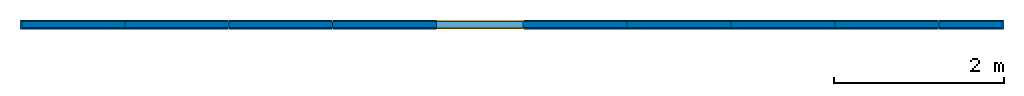
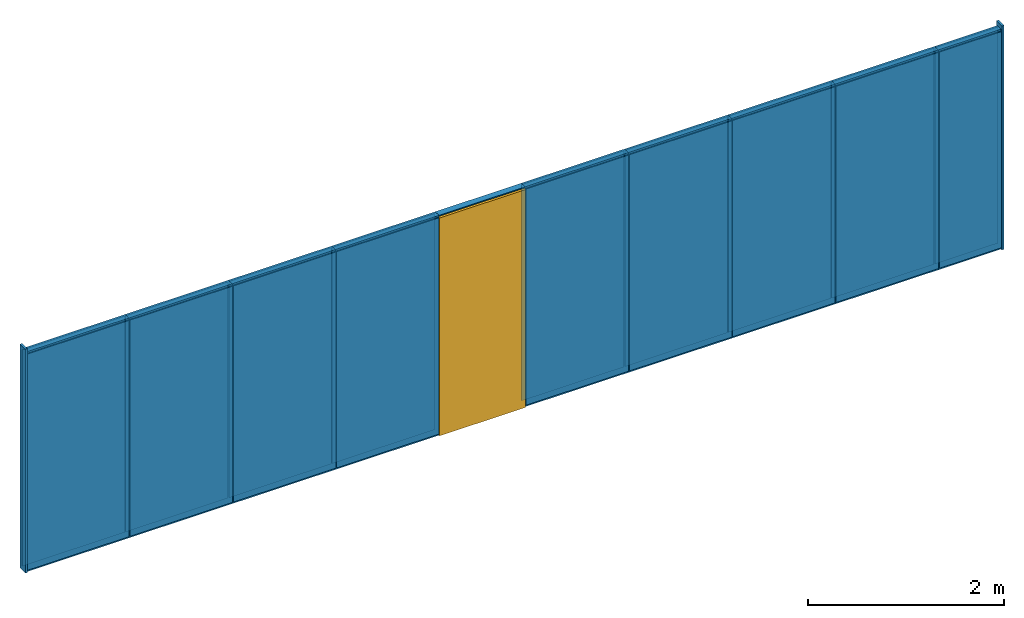
# One storey: 30 walls, 1 door, 1 opening, 1 element without a shape of its own.
"""IFC2X3 building model written with IfcOpenShell, lengths in inches."""

from ifc_helpers import new_model, entity, si_unit, converted_unit, direction, frame, origin, origin_with_axes, origin_2d_with_axis, place, context, subcontext, project, spatial, rectangle, extrude, source, transform, mapped, material, layer, layer_set, layer_usage, type_object, type_shapes, element, fill, aggregate, save


model = new_model("IFC2X3")

# Units and contexts
model_context = context("Model", 3, precision=1e-09, world=origin(), true_north=direction((0.0, 1.0, 0.0)))
context_of_model = context(None, 3, precision=1e-09, world=origin(), true_north=direction((0.0, 1.0, 0.0)))
body_context = subcontext(model_context, "Body", "Model", "MODEL_VIEW")
ifc_project = project(units=[converted_unit("LENGTHUNIT", "inch", entity("IfcReal", 25.4), si_unit("LENGTHUNIT", "METRE", prefix="MILLI"), dimensions=[1, 0, 0, 0, 0, 0, 0]), converted_unit("AREAUNIT", "square foot", entity("IfcReal", 92903.04000000001), si_unit("AREAUNIT", "SQUARE_METRE", prefix="MILLI"), dimensions=[2, 0, 0, 0, 0, 0, 0]), converted_unit("VOLUMEUNIT", "cubic foot", entity("IfcReal", 28316846.592), si_unit("VOLUMEUNIT", "CUBIC_METRE", prefix="MILLI"), dimensions=[3, 0, 0, 0, 0, 0, 0]), converted_unit("PLANEANGLEUNIT", "DEGREE", entity("IfcReal", 0.0174532925199433), si_unit("PLANEANGLEUNIT", "RADIAN"), dimensions=[0, 0, 0, 0, 0, 0, 0]), si_unit("SOLIDANGLEUNIT", "STERADIAN"), si_unit("MASSUNIT", "GRAM"), si_unit("TIMEUNIT", "SECOND"), si_unit("THERMODYNAMICTEMPERATUREUNIT", "DEGREE_CELSIUS"), si_unit("LUMINOUSINTENSITYUNIT", "LUMEN")], contexts=[model_context, context_of_model])

# Site, building, storey
site_placement = place(None, origin_with_axes())
site = spatial("IfcSite", under=ifc_project, at=site_placement, CompositionType="ELEMENT")
building_placement = place(None, origin_with_axes())
building = spatial("IfcBuilding", under=site, at=building_placement, Name="Default Building", CompositionType="ELEMENT")
storey_placement = place(building_placement, origin_with_axes())
storey = spatial("IfcBuildingStorey", under=building, at=storey_placement, Name="Level 1", CompositionType="ELEMENT", Elevation=0.0)

# Walls
wall_type_1 = type_object("IfcWallType", Name="Generic Wall", PredefinedType="NOTDEFINED")
placement_1 = place(storey_placement, origin_with_axes())
wall_1 = element("IfcWallStandardCase", 1, at=placement_1, inside=storey, type_object=wall_type_1, Name="Wall WallSet Option", ObjectType="Wall WallSet Option")
wall_type_2 = type_object("IfcWallType", PredefinedType="NOTDEFINED")
wall_2_placement = place(placement_1, origin_with_axes())
wall_2 = element("IfcWall", 2, at=wall_2_placement, type_object=wall_type_2, context=body_context, shape_type="SweptSolid", body=[
    extrude(rectangle(XDim=29.640015, YDim=3.0, at=origin_2d_with_axis()), frame((211.547287, 0.0, 0.0), z_axis=(0.0, 0.0, 1.0), x_axis=(1.0, 0.0, 0.0)), (0.0, 0.0, 1.0), 108.0),
])
wall_type_3 = type_object("IfcWallType", PredefinedType="NOTDEFINED")
wall_3_placement = place(placement_1, origin_with_axes())
wall_3 = element("IfcWall", 3, at=wall_3_placement, type_object=wall_type_3, context=body_context, shape_type="SweptSolid", body=[
    extrude(rectangle(XDim=48.0, YDim=3.0, at=origin_2d_with_axis()), frame((-203.27272, 0.0, 0.0), z_axis=(0.0, 0.0, 1.0), x_axis=(1.0, 0.0, 0.0)), (0.0, 0.0, 1.0), 108.0),
])
wall_4_placement = place(placement_1, origin_with_axes())
wall_4 = element("IfcWall", 4, at=wall_4_placement, type_object=wall_type_3, context=body_context, shape_type="SweptSolid", body=[
    extrude(rectangle(XDim=48.0, YDim=3.0, at=origin_2d_with_axis()), frame((-107.27272, 0.0, 0.0), z_axis=(0.0, 0.0, 1.0), x_axis=(1.0, 0.0, 0.0)), (0.0, 0.0, 1.0), 108.0),
])
wall_5_placement = place(placement_1, origin_with_axes())
wall_5 = element("IfcWall", 5, at=wall_5_placement, type_object=wall_type_3, context=body_context, shape_type="SweptSolid", body=[
    extrude(rectangle(XDim=48.0, YDim=3.0, at=origin_2d_with_axis()), frame((124.72728, 0.0, 0.0), z_axis=(0.0, 0.0, 1.0), x_axis=(1.0, 0.0, 0.0)), (0.0, 0.0, 1.0), 108.0),
])
wall_6_placement = place(placement_1, origin_with_axes())
wall_6 = element("IfcWall", 6, at=wall_6_placement, type_object=wall_type_3, context=body_context, shape_type="SweptSolid", body=[
    extrude(rectangle(XDim=48.0, YDim=3.0, at=origin_2d_with_axis()), frame((-59.27272, 0.0, 0.0), z_axis=(0.0, 0.0, 1.0), x_axis=(1.0, 0.0, 0.0)), (0.0, 0.0, 1.0), 108.0),
])
wall_7_placement = place(placement_1, origin_with_axes())
wall_7 = element("IfcWall", 7, at=wall_7_placement, type_object=wall_type_3, context=body_context, shape_type="SweptSolid", body=[
    extrude(rectangle(XDim=48.0, YDim=3.0, at=origin_2d_with_axis()), frame((76.72728, 0.0, 0.0), z_axis=(0.0, 0.0, 1.0), x_axis=(1.0, 0.0, 0.0)), (0.0, 0.0, 1.0), 108.0),
])
wall_8_placement = place(placement_1, origin_with_axes())
wall_8 = element("IfcWall", 8, at=wall_8_placement, type_object=wall_type_3, context=body_context, shape_type="SweptSolid", body=[
    extrude(rectangle(XDim=48.0, YDim=3.0, at=origin_2d_with_axis()), frame((172.72728, 0.0, 0.0), z_axis=(0.0, 0.0, 1.0), x_axis=(1.0, 0.0, 0.0)), (0.0, 0.0, 1.0), 108.0),
])
wall_9_placement = place(placement_1, origin_with_axes())
wall_9 = element("IfcWall", 9, at=wall_9_placement, type_object=wall_type_3, context=body_context, shape_type="SweptSolid", body=[
    extrude(rectangle(XDim=48.0, YDim=3.0, at=origin_2d_with_axis()), frame((-155.27272, 0.0, 0.0), z_axis=(0.0, 0.0, 1.0), x_axis=(1.0, 0.0, 0.0)), (0.0, 0.0, 1.0), 108.0),
])
wall_10_placement = place(placement_1, origin_with_axes())
wall_10 = element("IfcWall", 10, at=wall_10_placement, type_object=wall_type_3, context=body_context, shape_type="SweptSolid", body=[
    extrude(rectangle(XDim=48.0, YDim=3.0, at=origin_2d_with_axis()), frame((28.72728, 0.0, 0.0), z_axis=(0.0, 0.0, 1.0), x_axis=(1.0, 0.0, 0.0)), (0.0, 0.0, 1.0), 108.0),
])

# Wall
element("IfcWallStandardCase", 11, at=placement_1, inside=storey, Name="X-Wing End Cap", ObjectType="X-Wing End Cap", context=body_context, shape_type="SweptSolid", body=[
    extrude(rectangle(XDim=4.35, YDim=0.9748, at=origin_2d_with_axis()), frame((226.367294, 0.0, 0.0), z_axis=(0.0, 0.0, 1.0), x_axis=(0.0, -1.0, 0.0)), (0.0, 0.0, 1.0), 109.968506),
])

wall_12_placement = place(placement_1, origin_with_axes())
wall_12 = element("IfcWallStandardCase", 12, at=wall_12_placement, Name="Wall Face Mounted Tile Option", ObjectType="Wall Face Mounted Tile Option", context=body_context, shape_type="SweptSolid", body=[
    extrude(rectangle(XDim=29.285683, YDim=0.5, at=origin_2d_with_axis()), frame((211.545898, -1.75, 1.0), z_axis=(0.0, 0.0, 1.0), x_axis=(1.0, 0.0, 0.0)), (0.0, 0.0, 1.0), 106.198814),
])

wall_13_placement = place(placement_1, origin_with_axes())
wall_13 = element("IfcWallStandardCase", 13, at=wall_13_placement, Name="Wall Face Mounted Tile Option", ObjectType="Wall Face Mounted Tile Option", context=body_context, shape_type="SweptSolid", body=[
    extrude(rectangle(XDim=29.285683, YDim=0.5, at=origin_2d_with_axis()), frame((211.548676, 1.749999, 1.0), z_axis=(0.0, 0.0, 1.0), x_axis=(-1.0, 0.0, 0.0)), (0.0, 0.0, 1.0), 106.198814),
])

wall_14_placement = place(placement_1, origin_with_axes())
wall_14 = element("IfcWallStandardCase", 14, at=wall_14_placement, Name="Wall Face Mounted Tile Option", ObjectType="Wall Face Mounted Tile Option", context=body_context, shape_type="SweptSolid", body=[
    extrude(rectangle(XDim=47.645668, YDim=0.5, at=origin_2d_with_axis()), frame((-203.274109, -1.75, 1.0), z_axis=(0.0, 0.0, 1.0), x_axis=(1.0, 0.0, 0.0)), (0.0, 0.0, 1.0), 106.198814),
])

wall_15_placement = place(placement_1, origin_with_axes())
wall_15 = element("IfcWallStandardCase", 15, at=wall_15_placement, Name="Wall Face Mounted Tile Option", ObjectType="Wall Face Mounted Tile Option", context=body_context, shape_type="SweptSolid", body=[
    extrude(rectangle(XDim=47.645668, YDim=0.5, at=origin_2d_with_axis()), frame((-203.271332, 1.749998, 1.0), z_axis=(0.0, 0.0, 1.0), x_axis=(-1.0, 0.0, 0.0)), (0.0, 0.0, 1.0), 106.198814),
])

wall_16_placement = place(placement_1, origin_with_axes())
wall_16 = element("IfcWallStandardCase", 16, at=wall_16_placement, Name="Wall Face Mounted Tile Option", ObjectType="Wall Face Mounted Tile Option", context=body_context, shape_type="SweptSolid", body=[
    extrude(rectangle(XDim=47.645668, YDim=0.5, at=origin_2d_with_axis()), frame((-107.274109, -1.75, 1.0), z_axis=(0.0, 0.0, 1.0), x_axis=(1.0, 0.0, 0.0)), (0.0, 0.0, 1.0), 106.198814),
])

wall_17_placement = place(placement_1, origin_with_axes())
wall_17 = element("IfcWallStandardCase", 17, at=wall_17_placement, Name="Wall Face Mounted Tile Option", ObjectType="Wall Face Mounted Tile Option", context=body_context, shape_type="SweptSolid", body=[
    extrude(rectangle(XDim=47.645668, YDim=0.5, at=origin_2d_with_axis()), frame((-107.271339, 1.749998, 1.0), z_axis=(0.0, 0.0, 1.0), x_axis=(-1.0, 0.0, 0.0)), (0.0, 0.0, 1.0), 106.198814),
])

wall_18_placement = place(placement_1, origin_with_axes())
wall_18 = element("IfcWallStandardCase", 18, at=wall_18_placement, Name="Wall Face Mounted Tile Option", ObjectType="Wall Face Mounted Tile Option", context=body_context, shape_type="SweptSolid", body=[
    extrude(rectangle(XDim=47.645668, YDim=0.5, at=origin_2d_with_axis()), frame((124.725899, -1.75, 1.0), z_axis=(0.0, 0.0, 1.0), x_axis=(1.0, 0.0, 0.0)), (0.0, 0.0, 1.0), 106.198814),
])

wall_19_placement = place(placement_1, origin_with_axes())
wall_19 = element("IfcWallStandardCase", 19, at=wall_19_placement, Name="Wall Face Mounted Tile Option", ObjectType="Wall Face Mounted Tile Option", context=body_context, shape_type="SweptSolid", body=[
    extrude(rectangle(XDim=47.645668, YDim=0.5, at=origin_2d_with_axis()), frame((124.728668, 1.749998, 1.0), z_axis=(0.0, 0.0, 1.0), x_axis=(-1.0, 0.0, 0.0)), (0.0, 0.0, 1.0), 106.198814),
])

wall_20_placement = place(placement_1, origin_with_axes())
wall_20 = element("IfcWallStandardCase", 20, at=wall_20_placement, Name="Wall Face Mounted Tile Option", ObjectType="Wall Face Mounted Tile Option", context=body_context, shape_type="SweptSolid", body=[
    extrude(rectangle(XDim=47.645668, YDim=0.5, at=origin_2d_with_axis()), frame((-59.274105, -1.75, 1.0), z_axis=(0.0, 0.0, 1.0), x_axis=(1.0, 0.0, 0.0)), (0.0, 0.0, 1.0), 106.198814),
])

wall_21_placement = place(placement_1, origin_with_axes())
wall_21 = element("IfcWallStandardCase", 21, at=wall_21_placement, Name="Wall Face Mounted Tile Option", ObjectType="Wall Face Mounted Tile Option", context=body_context, shape_type="SweptSolid", body=[
    extrude(rectangle(XDim=47.645668, YDim=0.5, at=origin_2d_with_axis()), frame((-59.271336, 1.749998, 1.0), z_axis=(0.0, 0.0, 1.0), x_axis=(-1.0, 0.0, 0.0)), (0.0, 0.0, 1.0), 106.198814),
])

wall_22_placement = place(placement_1, origin_with_axes())
wall_22 = element("IfcWallStandardCase", 22, at=wall_22_placement, Name="Wall Face Mounted Tile Option", ObjectType="Wall Face Mounted Tile Option", context=body_context, shape_type="SweptSolid", body=[
    extrude(rectangle(XDim=47.645668, YDim=0.5, at=origin_2d_with_axis()), frame((76.725891, -1.75, 1.0), z_axis=(0.0, 0.0, 1.0), x_axis=(1.0, 0.0, 0.0)), (0.0, 0.0, 1.0), 106.198814),
])

wall_23_placement = place(placement_1, origin_with_axes())
wall_23 = element("IfcWallStandardCase", 23, at=wall_23_placement, Name="Wall Face Mounted Tile Option", ObjectType="Wall Face Mounted Tile Option", context=body_context, shape_type="SweptSolid", body=[
    extrude(rectangle(XDim=47.645668, YDim=0.5, at=origin_2d_with_axis()), frame((76.728668, 1.749998, 1.0), z_axis=(0.0, 0.0, 1.0), x_axis=(-1.0, 0.0, 0.0)), (0.0, 0.0, 1.0), 106.198814),
])

wall_24_placement = place(placement_1, origin_with_axes())
wall_24 = element("IfcWallStandardCase", 24, at=wall_24_placement, Name="Wall Face Mounted Tile Option", ObjectType="Wall Face Mounted Tile Option", context=body_context, shape_type="SweptSolid", body=[
    extrude(rectangle(XDim=47.645668, YDim=0.5, at=origin_2d_with_axis()), frame((172.725891, -1.75, 1.0), z_axis=(0.0, 0.0, 1.0), x_axis=(1.0, 0.0, 0.0)), (0.0, 0.0, 1.0), 106.198814),
])

wall_25_placement = place(placement_1, origin_with_axes())
wall_25 = element("IfcWallStandardCase", 25, at=wall_25_placement, Name="Wall Face Mounted Tile Option", ObjectType="Wall Face Mounted Tile Option", context=body_context, shape_type="SweptSolid", body=[
    extrude(rectangle(XDim=47.645668, YDim=0.5, at=origin_2d_with_axis()), frame((172.728668, 1.749998, 1.0), z_axis=(0.0, 0.0, 1.0), x_axis=(-1.0, 0.0, 0.0)), (0.0, 0.0, 1.0), 106.198814),
])

wall_26_placement = place(placement_1, origin_with_axes())
wall_26 = element("IfcWallStandardCase", 26, at=wall_26_placement, Name="Wall Face Mounted Tile Option", ObjectType="Wall Face Mounted Tile Option", context=body_context, shape_type="SweptSolid", body=[
    extrude(rectangle(XDim=47.645668, YDim=0.5, at=origin_2d_with_axis()), frame((-155.274109, -1.75, 1.0), z_axis=(0.0, 0.0, 1.0), x_axis=(1.0, 0.0, 0.0)), (0.0, 0.0, 1.0), 106.198814),
])

wall_27_placement = place(placement_1, origin_with_axes())
wall_27 = element("IfcWallStandardCase", 27, at=wall_27_placement, Name="Wall Face Mounted Tile Option", ObjectType="Wall Face Mounted Tile Option", context=body_context, shape_type="SweptSolid", body=[
    extrude(rectangle(XDim=47.645668, YDim=0.5, at=origin_2d_with_axis()), frame((-155.271332, 1.749998, 1.0), z_axis=(0.0, 0.0, 1.0), x_axis=(-1.0, 0.0, 0.0)), (0.0, 0.0, 1.0), 106.198814),
])

# Wall, opening, door
ifc_material = material()
ifc_layer = layer(ifc_material, 0.6667)
ifc_layer_set = layer_set([ifc_layer])
ifc_layer_usage = layer_usage(ifc_layer_set, "AXIS2", "NEGATIVE", 0.3333333)
placement_2 = place(placement_1, origin_with_axes())
wall_28 = element("IfcWallStandardCase", 28, at=placement_2, inside=storey, material=ifc_layer_usage, context=body_context, shape_type="SweptSolid", body=[
    extrude(rectangle(XDim=40.0, YDim=3.0, at=origin_2d_with_axis()), frame((-15.27272, 0.0, 0.0), z_axis=(0.0, 0.0, 1.0), x_axis=(1.0, 0.0, 0.0)), (0.0, 0.0, 1.0), 108.0),
])
opening = element("IfcOpeningElement", 29, at=placement_2, cuts=wall_28, ObjectType="Opening", context=body_context, shape_type="SweptSolid", body=[
    extrude(rectangle(XDim=40.0, YDim=4.0, at=origin_2d_with_axis()), frame((-15.27272, 0.0, 0.0), z_axis=(0.0, 0.0, 1.0), x_axis=(1.0, 0.0, 0.0)), (0.0, 0.0, 1.0), 107.5),
])
door_style = type_object("IfcDoorStyle", ConstructionType="NOTDEFINED", OperationType="SINGLE_SWING_LEFT", ParameterTakesPrecedence=False, Sizeable=False)
shared_shape = source(origin(), model_context, "Body", "SweptSolid", [
    extrude(rectangle(XDim=40.0, YDim=4.0, at=origin_2d_with_axis()), frame((20.0, 0.0, 0.0), z_axis=(0.0, 0.0, 1.0), x_axis=(1.0, 0.0, 0.0)), (0.0, 0.0, 1.0), 107.0),
])
type_shapes(door_style, [shared_shape])
door_placement = place(placement_2, frame((-35.27272, 0.0, 0.0), z_axis=(0.0, 0.0, 1.0), x_axis=(1.0, 0.0, 0.0)))
door = element("IfcDoor", 30, at=door_placement, inside=storey, type_object=door_style, OverallHeight=105.65551, OverallWidth=40.0, context=body_context, shape_type="MappedRepresentation", body=[
    mapped(shared_shape, transform((0.0, 0.0, 0.0), scale=1.0)),
])
fill(opening, door)

# Wall
wall_29_placement = place(placement_1, origin_with_axes())
wall_29 = element("IfcWallStandardCase", 31, at=wall_29_placement, Name="Wall Face Mounted Tile Option", ObjectType="Wall Face Mounted Tile Option", context=body_context, shape_type="SweptSolid", body=[
    extrude(rectangle(XDim=47.645668, YDim=0.5, at=origin_2d_with_axis()), frame((28.725895, -1.75, 1.0), z_axis=(0.0, 0.0, 1.0), x_axis=(1.0, 0.0, 0.0)), (0.0, 0.0, 1.0), 106.198814),
])

wall_30_placement = place(placement_1, origin_with_axes())
wall_30 = element("IfcWallStandardCase", 32, at=wall_30_placement, Name="Wall Face Mounted Tile Option", ObjectType="Wall Face Mounted Tile Option", context=body_context, shape_type="SweptSolid", body=[
    extrude(rectangle(XDim=47.645668, YDim=0.5, at=origin_2d_with_axis()), frame((28.728664, 1.749998, 1.0), z_axis=(0.0, 0.0, 1.0), x_axis=(-1.0, 0.0, 0.0)), (0.0, 0.0, 1.0), 106.198814),
])

aggregate(wall_1, [wall_2, wall_12, wall_13, wall_3, wall_14, wall_15, wall_4, wall_16, wall_17, wall_5, wall_18, wall_19, wall_6, wall_20, wall_21, wall_7, wall_22, wall_23, wall_8, wall_24, wall_25, wall_9, wall_26, wall_27, wall_10, wall_29, wall_30])

element("IfcWallStandardCase", 33, at=placement_1, inside=storey, Name="X-Wing End Cap", ObjectType="X-Wing End Cap", context=body_context, shape_type="SweptSolid", body=[
    extrude(rectangle(XDim=4.35, YDim=0.9748, at=origin_2d_with_axis()), frame((-227.27272, 0.0, 0.0), z_axis=(0.0, 0.0, 1.0), x_axis=(0.0, 1.0, 0.0)), (0.0, 0.0, 1.0), 109.968506),
])

save(model, "model.ifc")
